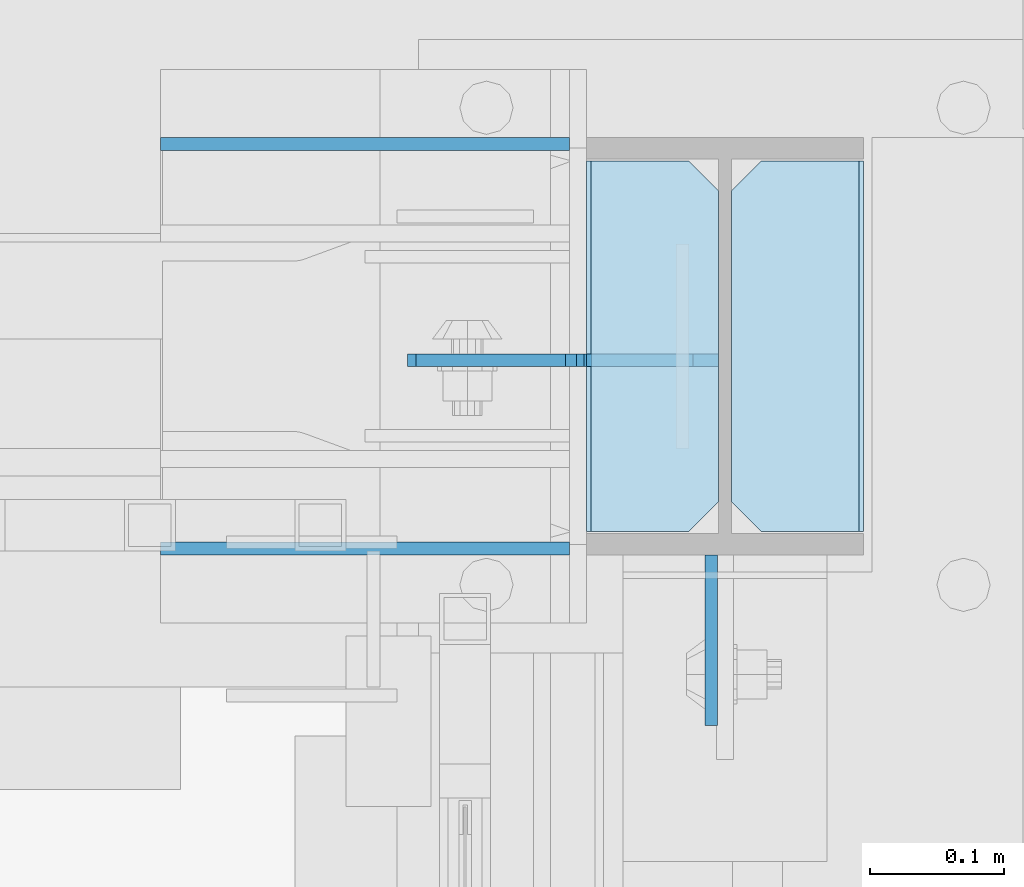
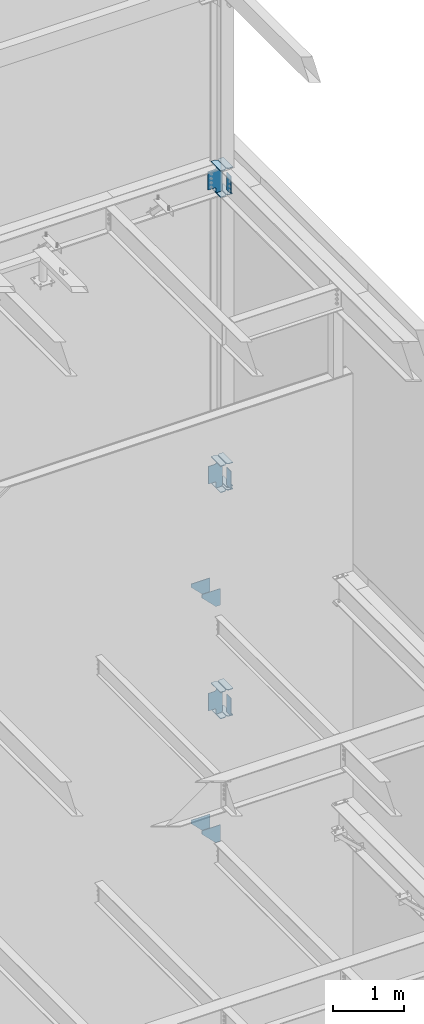
# One storey, part 1116 of 1179: 23 plates, 1 element without a shape of its own.
"""IFC2X3 building model written with IfcOpenShell, lengths in millimetres."""

from ifc_helpers import new_model, si_unit, frame, origin_with_axes, place, context, subcontext, project, spatial, faceted_brep, material, type_object, element, aggregate, save


model = new_model("IFC2X3")

# Units and contexts
model_context = context("Model", 3, precision=1e-05, world=origin_with_axes())
body_context = subcontext(model_context, "Body", "Model", "MODEL_VIEW")
ifc_project = project(units=[si_unit("LENGTHUNIT", "METRE", prefix="MILLI"), si_unit("AREAUNIT", "SQUARE_METRE"), si_unit("VOLUMEUNIT", "CUBIC_METRE"), si_unit("MASSUNIT", "GRAM", prefix="KILO"), si_unit("TIMEUNIT", "SECOND"), si_unit("PLANEANGLEUNIT", "RADIAN"), si_unit("SOLIDANGLEUNIT", "STERADIAN"), si_unit("THERMODYNAMICTEMPERATUREUNIT", "DEGREE_CELSIUS"), si_unit("LUMINOUSINTENSITYUNIT", "LUMEN")], contexts=[model_context])

# Site, building, storey
site_placement = place(None, origin_with_axes())
site = spatial("IfcSite", under=ifc_project, at=site_placement, CompositionType="ELEMENT")
building_placement = place(site_placement, origin_with_axes())
building = spatial("IfcBuilding", under=site, at=building_placement, Name="Undefined", CompositionType="ELEMENT")
storey_placement = place(building_placement, origin_with_axes())
storey = spatial("IfcBuildingStorey", under=building, at=storey_placement, Name="Undefined", CompositionType="ELEMENT", Elevation=0.0)

# Assembly, plates
assembly_placement = place(storey_placement, origin_with_axes())
assembly = element("IfcElementAssembly", 1, at=assembly_placement, inside=storey, Name="COLUMN", AssemblyPlace="NOTDEFINED", PredefinedType="RIGID_FRAME")
ifc_material = material(Name="STEEL/A36")
plate_type_1 = type_object("IfcPlateType", PredefinedType="NOTDEFINED")
plate_1_placement = place(assembly_placement, frame((24297.48125, 41043.225, 13081.0), z_axis=(0.0, -1.0, 0.0), x_axis=(0.0, 0.0, -1.0)))
plate_1 = element("IfcPlate", 2, at=plate_1_placement, type_object=plate_type_1, material=ifc_material, Name="PLATE", context=body_context, shape_type="Brep", body=[
    faceted_brep([(0.0, -4.76249999999709, 0.0), (0.0, -4.76249999999709, 127.0), (0.0, 4.76249999999709, 127.0), (0.0, 4.76249999999709, 0.0), (304.799999999999, -4.76249999999982, 127.0), (304.799999999999, 4.76249999999982, 127.0), (304.799987792969, -4.76250000000073, 0.0), (304.799987792969, 4.76250000000073, 0.0)], [[[0, 1, 2, 3]], [[2, 1, 4, 5]], [[4, 6, 7, 5]], [[6, 0, 3, 7]], [[5, 7, 3, 2]], [[6, 4, 1, 0]]]),
])
plate_2_placement = place(assembly_placement, frame((24297.48125, 41043.225, 7975.5999983942), z_axis=(0.0, -1.0, 0.0), x_axis=(0.0, 0.0, -1.0)))
plate_2 = element("IfcPlate", 3, at=plate_2_placement, type_object=plate_type_1, material=ifc_material, Name="PLATE", context=body_context, shape_type="Brep", body=[
    faceted_brep([(0.0, -4.76249999999709, 0.0), (0.0, -4.76249999999709, 127.0), (0.0, 4.76249999999709, 127.0), (0.0, 4.76249999999709, 0.0), (304.799999999999, -4.76249999999982, 127.0), (304.799999999999, 4.76249999999982, 127.0), (304.799987792969, -4.76250000000073, 0.0), (304.799987792969, 4.76250000000073, 0.0)], [[[0, 1, 2, 3]], [[2, 1, 4, 5]], [[4, 6, 7, 5]], [[6, 0, 3, 7]], [[5, 7, 3, 2]], [[6, 4, 1, 0]]]),
])
plate_3_placement = place(assembly_placement, frame((24297.48125, 41043.225, 4051.3), z_axis=(0.0, -1.0, 0.0), x_axis=(0.0, 0.0, -1.0)))
plate_3 = element("IfcPlate", 4, at=plate_3_placement, type_object=plate_type_1, material=ifc_material, Name="PLATE", context=body_context, shape_type="Brep", body=[
    faceted_brep([(0.0, -4.76249999999709, 0.0), (0.0, -4.76249999999709, 127.0), (0.0, 4.76249999999709, 127.0), (0.0, 4.76249999999709, 0.0), (304.799999999999, -4.76249999999982, 127.0), (304.799999999999, 4.76249999999982, 127.0), (304.799987792969, -4.76250000000073, 0.0), (304.799987792969, 4.76250000000073, 0.0)], [[[0, 1, 2, 3]], [[2, 1, 4, 5]], [[4, 6, 7, 5]], [[6, 0, 3, 7]], [[5, 7, 3, 2]], [[6, 4, 1, 0]]]),
])
plate_type_2 = type_object("IfcPlateType", PredefinedType="NOTDEFINED")
plate_4_placement = place(assembly_placement, frame((24312.5625, 41336.9125, 12658.725), z_axis=(0.0, -1.0, 0.0), x_axis=(1.0, 0.0, 0.0)))
plate_4 = element("IfcPlate", 5, at=plate_4_placement, type_object=plate_type_2, material=ifc_material, Name="PLATE", context=body_context, shape_type="Brep", body=[
    faceted_brep([(0.0, -6.34999999999854, 22.2250003814697), (0.0, -6.35000000000036, 254.000005722046), (0.0, 6.35000000000036, 254.000005722046), (0.0, 6.34999999999854, 22.2250003814697), (22.2250003814697, -6.35000000000036, 276.225006103516), (22.2250003814697, 6.35000000000036, 276.225006103516), (95.25, -6.35000000000036, 276.225006103516), (95.25, 6.35000000000036, 276.225006103516), (95.25, -6.34999999999309, 1.81898940354586e-12), (95.25, 6.34999999999854, -1.81898940354586e-12), (22.2250003814697, -6.34999999999854, 0.0), (22.2250003814697, 6.34999999999854, 0.0)], [[[0, 1, 2, 3]], [[1, 4, 5, 2]], [[4, 6, 7, 5]], [[6, 8, 9, 7]], [[8, 10, 11, 9]], [[10, 0, 3, 11]], [[5, 7, 9, 11, 3, 2]], [[10, 8, 6, 4, 1, 0]]]),
])
plate_5_placement = place(assembly_placement, frame((24312.5625, 41336.9125, 13112.75), z_axis=(0.0, -1.0, 0.0), x_axis=(1.0, 0.0, 0.0)))
plate_5 = element("IfcPlate", 6, at=plate_5_placement, type_object=plate_type_2, material=ifc_material, Name="PLATE", context=body_context, shape_type="Brep", body=[
    faceted_brep([(0.0, -6.34999999999854, 22.2250003814697), (0.0, -6.35000000000036, 254.000005722046), (0.0, 6.35000000000036, 254.000005722046), (0.0, 6.34999999999854, 22.2250003814697), (22.2250003814697, -6.35000000000036, 276.225006103516), (22.2250003814697, 6.35000000000036, 276.225006103516), (95.25, -6.35000000000036, 276.225006103516), (95.25, 6.35000000000036, 276.225006103516), (95.25, -6.34999999999309, 1.81898940354586e-12), (95.25, 6.34999999999854, -1.81898940354586e-12), (22.2250003814697, -6.34999999999854, 0.0), (22.2250003814697, 6.34999999999854, 0.0)], [[[0, 1, 2, 3]], [[1, 4, 5, 2]], [[4, 6, 7, 5]], [[6, 8, 9, 7]], [[8, 10, 11, 9]], [[10, 0, 3, 11]], [[5, 7, 9, 11, 3, 2]], [[10, 8, 6, 4, 1, 0]]]),
])
plate_6_placement = place(assembly_placement, frame((24207.7875, 41336.9125, 12658.725), z_axis=(0.0, -1.0, 0.0), x_axis=(1.0, 0.0, 0.0)))
plate_6 = element("IfcPlate", 7, at=plate_6_placement, type_object=plate_type_2, material=ifc_material, Name="PLATE", context=body_context, shape_type="Brep", body=[
    faceted_brep([(0.0, -6.34999999999854, 0.0), (0.0, -6.35000000000036, 276.225006103516), (0.0, 6.35000000000036, 276.225006103516), (0.0, 6.34999999999854, 0.0), (73.0249996185303, -6.35000000000036, 276.225006103516), (73.0249996185303, 6.35000000000036, 276.225006103516), (95.25, -6.35000000000036, 254.000005722046), (95.25, 6.35000000000036, 254.000005722046), (95.25, -6.35000000000036, 22.2250003814697), (95.25, 6.35000000000036, 22.2250003814697), (73.0249999999996, -6.34999999999854, 0.0), (73.0249999999996, 6.34999999999854, 0.0)], [[[0, 1, 2, 3]], [[1, 4, 5, 2]], [[4, 6, 7, 5]], [[6, 8, 9, 7]], [[8, 10, 11, 9]], [[10, 0, 3, 11]], [[5, 7, 9, 11, 3, 2]], [[10, 8, 6, 4, 1, 0]]]),
])
plate_7_placement = place(assembly_placement, frame((24207.7875, 41336.9125, 13112.75), z_axis=(0.0, -1.0, 0.0), x_axis=(1.0, 0.0, 0.0)))
plate_7 = element("IfcPlate", 8, at=plate_7_placement, type_object=plate_type_2, material=ifc_material, Name="PLATE", context=body_context, shape_type="Brep", body=[
    faceted_brep([(0.0, -6.34999999999854, 0.0), (0.0, -6.35000000000036, 276.225006103516), (0.0, 6.35000000000036, 276.225006103516), (0.0, 6.34999999999854, 0.0), (73.0249996185303, -6.35000000000036, 276.225006103516), (73.0249996185303, 6.35000000000036, 276.225006103516), (95.25, -6.35000000000036, 254.000005722046), (95.25, 6.35000000000036, 254.000005722046), (95.25, -6.35000000000036, 22.2250003814697), (95.25, 6.35000000000036, 22.2250003814697), (73.0249999999996, -6.34999999999854, 0.0), (73.0249999999996, 6.34999999999854, 0.0)], [[[0, 1, 2, 3]], [[1, 4, 5, 2]], [[4, 6, 7, 5]], [[6, 8, 9, 7]], [[8, 10, 11, 9]], [[10, 0, 3, 11]], [[5, 7, 9, 11, 3, 2]], [[10, 8, 6, 4, 1, 0]]]),
])
plate_8_placement = place(assembly_placement, frame((24407.8125, 41060.6875, 7604.125), z_axis=(0.0, 1.0, 0.0), x_axis=(-1.0, 0.0, 0.0)))
plate_8 = element("IfcPlate", 9, at=plate_8_placement, type_object=plate_type_2, material=ifc_material, Name="PLATE", context=body_context, shape_type="Brep", body=[
    faceted_brep([(0.0, -6.34999999999854, 0.0), (0.0, -6.35000000000036, 276.225006103516), (0.0, 6.35000000000036, 276.225006103516), (0.0, 6.34999999999854, 0.0), (73.0249996185303, -6.35000000000036, 276.225006103516), (73.0249996185303, 6.35000000000036, 276.225006103516), (95.25, -6.35000000000036, 254.000005722046), (95.25, 6.35000000000036, 254.000005722046), (95.25, -6.35000000000036, 22.2250003814697), (95.25, 6.35000000000036, 22.2250003814697), (73.0249999999996, -6.34999999999854, 0.0), (73.0249999999996, 6.34999999999854, 0.0)], [[[0, 1, 2, 3]], [[1, 4, 5, 2]], [[4, 6, 7, 5]], [[6, 8, 9, 7]], [[8, 10, 11, 9]], [[10, 0, 3, 11]], [[5, 7, 9, 11, 3, 2]], [[10, 8, 6, 4, 1, 0]]]),
])
plate_9_placement = place(assembly_placement, frame((24312.5625, 41336.9125, 7553.325), z_axis=(0.0, -1.0, 0.0), x_axis=(1.0, 0.0, 0.0)))
plate_9 = element("IfcPlate", 10, at=plate_9_placement, type_object=plate_type_2, material=ifc_material, Name="PLATE", context=body_context, shape_type="Brep", body=[
    faceted_brep([(0.0, -6.34999999999854, 22.2250003814697), (0.0, -6.35000000000036, 254.000005722046), (0.0, 6.35000000000036, 254.000005722046), (0.0, 6.34999999999854, 22.2250003814697), (22.2250003814697, -6.35000000000036, 276.225006103516), (22.2250003814697, 6.35000000000036, 276.225006103516), (95.25, -6.35000000000036, 276.225006103516), (95.25, 6.35000000000036, 276.225006103516), (95.25, -6.34999999999309, 1.81898940354586e-12), (95.25, 6.34999999999854, -1.81898940354586e-12), (22.2250003814697, -6.34999999999854, 0.0), (22.2250003814697, 6.34999999999854, 0.0)], [[[0, 1, 2, 3]], [[1, 4, 5, 2]], [[4, 6, 7, 5]], [[6, 8, 9, 7]], [[8, 10, 11, 9]], [[10, 0, 3, 11]], [[5, 7, 9, 11, 3, 2]], [[10, 8, 6, 4, 1, 0]]]),
])
plate_10_placement = place(assembly_placement, frame((24312.5625, 41336.9125, 8007.35), z_axis=(0.0, -1.0, 0.0), x_axis=(1.0, 0.0, 0.0)))
plate_10 = element("IfcPlate", 11, at=plate_10_placement, type_object=plate_type_2, material=ifc_material, Name="PLATE", context=body_context, shape_type="Brep", body=[
    faceted_brep([(0.0, -6.34999999999854, 22.2250003814697), (0.0, -6.35000000000036, 254.000005722046), (0.0, 6.35000000000036, 254.000005722046), (0.0, 6.34999999999854, 22.2250003814697), (22.2250003814697, -6.35000000000036, 276.225006103516), (22.2250003814697, 6.35000000000036, 276.225006103516), (95.25, -6.35000000000036, 276.225006103516), (95.25, 6.35000000000036, 276.225006103516), (95.25, -6.34999999999309, 1.81898940354586e-12), (95.25, 6.34999999999854, -1.81898940354586e-12), (22.2250003814697, -6.34999999999854, 0.0), (22.2250003814697, 6.34999999999854, 0.0)], [[[0, 1, 2, 3]], [[1, 4, 5, 2]], [[4, 6, 7, 5]], [[6, 8, 9, 7]], [[8, 10, 11, 9]], [[10, 0, 3, 11]], [[5, 7, 9, 11, 3, 2]], [[10, 8, 6, 4, 1, 0]]]),
])
plate_11_placement = place(assembly_placement, frame((24207.7875, 41336.9125, 7553.325), z_axis=(0.0, -1.0, 0.0), x_axis=(1.0, 0.0, 0.0)))
plate_11 = element("IfcPlate", 12, at=plate_11_placement, type_object=plate_type_2, material=ifc_material, Name="PLATE", context=body_context, shape_type="Brep", body=[
    faceted_brep([(0.0, -6.34999999999854, 0.0), (0.0, -6.35000000000036, 276.225006103516), (0.0, 6.35000000000036, 276.225006103516), (0.0, 6.34999999999854, 0.0), (73.0249996185303, -6.35000000000036, 276.225006103516), (73.0249996185303, 6.35000000000036, 276.225006103516), (95.25, -6.35000000000036, 254.000005722046), (95.25, 6.35000000000036, 254.000005722046), (95.25, -6.35000000000036, 22.2250003814697), (95.25, 6.35000000000036, 22.2250003814697), (73.0249999999996, -6.34999999999854, 0.0), (73.0249999999996, 6.34999999999854, 0.0)], [[[0, 1, 2, 3]], [[1, 4, 5, 2]], [[4, 6, 7, 5]], [[6, 8, 9, 7]], [[8, 10, 11, 9]], [[10, 0, 3, 11]], [[5, 7, 9, 11, 3, 2]], [[10, 8, 6, 4, 1, 0]]]),
])
plate_12_placement = place(assembly_placement, frame((24207.7875, 41336.9125, 8007.35), z_axis=(0.0, -1.0, 0.0), x_axis=(1.0, 0.0, 0.0)))
plate_12 = element("IfcPlate", 13, at=plate_12_placement, type_object=plate_type_2, material=ifc_material, Name="PLATE", context=body_context, shape_type="Brep", body=[
    faceted_brep([(0.0, -6.34999999999854, 0.0), (0.0, -6.35000000000036, 276.225006103516), (0.0, 6.35000000000036, 276.225006103516), (0.0, 6.34999999999854, 0.0), (73.0249996185303, -6.35000000000036, 276.225006103516), (73.0249996185303, 6.35000000000036, 276.225006103516), (95.25, -6.35000000000036, 254.000005722046), (95.25, 6.35000000000036, 254.000005722046), (95.25, -6.35000000000036, 22.2250003814697), (95.25, 6.35000000000036, 22.2250003814697), (73.0249999999996, -6.34999999999854, 0.0), (73.0249999999996, 6.34999999999854, 0.0)], [[[0, 1, 2, 3]], [[1, 4, 5, 2]], [[4, 6, 7, 5]], [[6, 8, 9, 7]], [[8, 10, 11, 9]], [[10, 0, 3, 11]], [[5, 7, 9, 11, 3, 2]], [[10, 8, 6, 4, 1, 0]]]),
])
plate_type_3 = type_object("IfcPlateType", PredefinedType="NOTDEFINED")
plate_13_placement = place(assembly_placement, frame((24303.0375, 41188.4807500839, 7578.725), z_axis=(-0.707106781186532, 0.0, 0.707106781186563), x_axis=(-0.707106781186564, 0.0, -0.707106781186531)))
plate_13 = element("IfcPlate", 14, at=plate_13_placement, type_object=plate_type_3, material=ifc_material, Name="PLATE", context=body_context, shape_type="Brep", body=[
    faceted_brep([(0.0, -4.76249999999709, 0.0), (-285.12313184404, -4.76249999999709, 285.12313184404), (-285.12313184404, 4.76249999999709, 285.12313184404), (0.0, 4.76249999999709, 0.0), (-285.123131844106, -4.76249999999709, 312.063900207191), (-285.123131844106, 4.76249999999709, 312.063900207191), (-228.996531087698, -4.76249999999709, 368.190500963599), (-228.996531087698, 4.76249999999709, 368.190500963599), (-220.756177881638, -4.76249999999709, 362.684472892908), (-220.756177881638, 4.76249999999709, 362.684472892908), (-211.036018845556, -4.76249999999709, 360.751013047719), (-211.036018845556, 4.76249999999709, 360.751013047719), (-201.315859809478, -4.76249999999709, 362.684472892883), (-201.315859809478, 4.76249999999709, 362.684472892883), (-193.075506873185, -4.76249999999709, 368.19050069382), (-193.075506873185, 4.76249999999709, 368.19050069382), (-121.233457635277, -4.76249999999709, 440.03254993172), (-121.233457635277, 4.76249999999709, 440.03254993172), (94.2926892704454, -4.76249999999709, 224.506403025976), (94.2926892704454, 4.76249999999709, 224.506403025976), (22.4506400325372, -4.76249999999709, 152.664353788075), (22.4506400325372, 4.76249999999709, 152.664353788075), (16.9446122315967, -4.76249999999709, 144.424000851788), (16.9446122315967, 4.76249999999709, 144.424000851788), (15.0111523864362, -4.76249999999709, 134.703841815706), (15.0111523864362, 4.76249999999709, 134.703841815706), (16.9446122316185, -4.76249999999709, 124.983682779626), (16.9446122316185, 4.76249999999709, 124.983682779626), (22.4506400325808, -4.76249999999709, 116.743329843322), (22.4506400325808, 4.76249999999709, 116.743329843322), (83.0673691195552, -4.76249999999709, 56.126600756339), (83.0673691195552, 4.76249999999709, 56.126600756339), (26.9407683631525, -4.76249999999709, -6.18456397205591e-11), (26.9407683631525, 4.76249999999709, -6.18456397205591e-11)], [[[0, 1, 2, 3]], [[1, 4, 5, 2]], [[4, 6, 7, 5]], [[6, 8, 9, 7]], [[8, 10, 11, 9]], [[10, 12, 13, 11]], [[12, 14, 15, 13]], [[14, 16, 17, 15]], [[16, 18, 19, 17]], [[18, 20, 21, 19]], [[20, 22, 23, 21]], [[22, 24, 25, 23]], [[24, 26, 27, 25]], [[26, 28, 29, 27]], [[28, 30, 31, 29]], [[30, 32, 33, 31]], [[32, 0, 3, 33]], [[5, 7, 9, 11, 13, 15, 17, 19, 21, 23, 25, 27, 29, 31, 33, 3, 2]], [[32, 30, 28, 26, 24, 22, 20, 18, 16, 14, 12, 10, 8, 6, 4, 1, 0]]]),
])
plate_14_placement = place(assembly_placement, frame((24303.0375, 41188.4807500839, 3667.125), z_axis=(-0.707106781186532, 0.0, 0.707106781186563), x_axis=(-0.707106781186564, 0.0, -0.707106781186531)))
plate_14 = element("IfcPlate", 15, at=plate_14_placement, type_object=plate_type_3, material=ifc_material, Name="PLATE", context=body_context, shape_type="Brep", body=[
    faceted_brep([(0.0, -4.76249999999709, 0.0), (-285.12313184404, -4.76249999999709, 285.12313184404), (-285.12313184404, 4.76249999999709, 285.12313184404), (0.0, 4.76249999999709, 0.0), (-285.123131844106, -4.76249999999709, 312.063900207191), (-285.123131844106, 4.76249999999709, 312.063900207191), (-228.996531087698, -4.76249999999709, 368.190500963599), (-228.996531087698, 4.76249999999709, 368.190500963599), (-220.016274696889, -4.76249999999709, 359.210244572785), (-220.016274696889, 4.76249999999709, 359.210244572785), (-211.775921760582, -4.76249999999709, 353.704216771825), (-211.775921760582, 4.76249999999709, 353.704216771825), (-202.0557627245, -4.76249999999709, 351.770756926639), (-202.0557627245, 4.76249999999709, 351.770756926639), (-192.335603688422, -4.76249999999709, 353.704216771799), (-192.335603688422, 4.76249999999709, 353.704216771799), (-184.095250752132, -4.76249999999709, 359.21024457274), (-184.095250752132, 4.76249999999709, 359.21024457274), (-112.253201514228, -4.76249999999709, 431.052293810644), (-112.253201514228, 4.76249999999709, 431.052293810644), (103.272945391505, -4.76249999999709, 215.526146904915), (103.272945391505, 4.76249999999709, 215.526146904915), (31.4308961536044, -4.76249999999709, 143.68409766701), (31.4308961536044, 4.76249999999709, 143.68409766701), (25.9248683526639, -4.76249999999709, 135.443744730717), (25.9248683526639, 4.76249999999709, 135.443744730717), (23.9914085075034, -4.76249999999709, 125.723585694639), (23.9914085075034, 4.76249999999709, 125.723585694639), (25.924868352693, -4.76249999999709, 116.003426658557), (25.924868352693, 4.76249999999709, 116.003426658557), (31.4308961536517, -4.76249999999709, 107.763073722252), (31.4308961536517, 4.76249999999709, 107.763073722252), (83.0673691195552, -4.76249999999709, 56.126600756339), (83.0673691195552, 4.76249999999709, 56.126600756339), (26.9407683631525, -4.76249999999709, -6.18456397205591e-11), (26.9407683631525, 4.76249999999709, -6.18456397205591e-11)], [[[0, 1, 2, 3]], [[1, 4, 5, 2]], [[4, 6, 7, 5]], [[6, 8, 9, 7]], [[8, 10, 11, 9]], [[10, 12, 13, 11]], [[12, 14, 15, 13]], [[14, 16, 17, 15]], [[16, 18, 19, 17]], [[18, 20, 21, 19]], [[20, 22, 23, 21]], [[22, 24, 25, 23]], [[24, 26, 27, 25]], [[26, 28, 29, 27]], [[28, 30, 31, 29]], [[30, 32, 33, 31]], [[32, 34, 35, 33]], [[34, 0, 3, 35]], [[5, 7, 9, 11, 13, 15, 17, 19, 21, 23, 25, 27, 29, 31, 33, 35, 3, 2]], [[34, 32, 30, 28, 26, 24, 22, 20, 18, 16, 14, 12, 10, 8, 6, 4, 1, 0]]]),
])
plate_type_4 = type_object("IfcPlateType", PredefinedType="NOTDEFINED")
plate_15_placement = place(assembly_placement, frame((23887.112512207, 41349.6125, 5911.85), z_axis=(1.0, 0.0, 0.0), x_axis=(0.0, 0.0, -1.0)))
plate_15 = element("IfcPlate", 16, at=plate_15_placement, type_object=plate_type_4, material=ifc_material, Name="PLATE", context=body_context, shape_type="Brep", body=[
    faceted_brep([(0.0, -4.76249999999709, 0.0), (0.0, -4.76249999999709, 304.799987792969), (0.0, 4.76249999999709, 304.799987792969), (0.0, 4.76249999999709, 0.0), (285.75, -4.76249999999709, 304.799987792969), (285.75, 4.76249999999709, 304.799987792969), (285.75, -4.76249999999709, 228.736236572266), (285.75, 4.76249999999709, 228.736236572266), (57.1500015258789, -4.76250000000073, 0.0), (57.1500015258789, 4.76250000000073, 0.0)], [[[0, 1, 2, 3]], [[1, 4, 5, 2]], [[4, 6, 7, 5]], [[6, 8, 9, 7]], [[8, 0, 3, 9]], [[5, 7, 9, 3, 2]], [[8, 6, 4, 1, 0]]]),
])
plate_16_placement = place(assembly_placement, frame((23887.1125126018, 41047.9875, 5911.85), z_axis=(1.0, 0.0, 0.0), x_axis=(0.0, 0.0, -1.0)))
plate_16 = element("IfcPlate", 17, at=plate_16_placement, type_object=plate_type_4, material=ifc_material, Name="PLATE", context=body_context, shape_type="Brep", body=[
    faceted_brep([(0.0, -4.76249999999709, 0.0), (0.0, -4.76249999999709, 304.799987792969), (0.0, 4.76249999999709, 304.799987792969), (0.0, 4.76249999999709, 0.0), (285.75, -4.76249999999709, 304.799987792969), (285.75, 4.76249999999709, 304.799987792969), (285.75, -4.76249999999709, 228.736236572266), (285.75, 4.76249999999709, 228.736236572266), (57.1500015258789, -4.76250000000073, 0.0), (57.1500015258789, 4.76250000000073, 0.0)], [[[0, 1, 2, 3]], [[1, 4, 5, 2]], [[4, 6, 7, 5]], [[6, 8, 9, 7]], [[8, 0, 3, 9]], [[5, 7, 9, 3, 2]], [[8, 6, 4, 1, 0]]]),
])
plate_17_placement = place(assembly_placement, frame((23887.112512207, 41349.6125, 1825.625), z_axis=(1.0, 0.0, 0.0), x_axis=(0.0, 0.0, -1.0)))
plate_17 = element("IfcPlate", 18, at=plate_17_placement, type_object=plate_type_4, material=ifc_material, Name="PLATE", context=body_context, shape_type="Brep", body=[
    faceted_brep([(0.0, -4.76249999999709, 0.0), (0.0, -4.76249999999709, 304.799987792969), (0.0, 4.76249999999709, 304.799987792969), (0.0, 4.76249999999709, 0.0), (285.75, -4.76249999999709, 304.799987792969), (285.75, 4.76249999999709, 304.799987792969), (285.75, -4.76249999999709, 228.736236572266), (285.75, 4.76249999999709, 228.736236572266), (57.1500015258789, -4.76250000000073, 0.0), (57.1500015258789, 4.76250000000073, 0.0)], [[[0, 1, 2, 3]], [[1, 4, 5, 2]], [[4, 6, 7, 5]], [[6, 8, 9, 7]], [[8, 0, 3, 9]], [[5, 7, 9, 3, 2]], [[8, 6, 4, 1, 0]]]),
])
plate_18_placement = place(assembly_placement, frame((23887.1125126018, 41047.9875, 1825.625), z_axis=(1.0, 0.0, 0.0), x_axis=(0.0, 0.0, -1.0)))
plate_18 = element("IfcPlate", 19, at=plate_18_placement, type_object=plate_type_4, material=ifc_material, Name="PLATE", context=body_context, shape_type="Brep", body=[
    faceted_brep([(0.0, -4.76249999999709, 0.0), (0.0, -4.76249999999709, 304.799987792969), (0.0, 4.76249999999709, 304.799987792969), (0.0, 4.76249999999709, 0.0), (285.75, -4.76249999999709, 304.799987792969), (285.75, 4.76249999999709, 304.799987792969), (285.75, -4.76249999999709, 228.736236572266), (285.75, 4.76249999999709, 228.736236572266), (57.1500015258789, -4.76250000000073, 0.0), (57.1500015258789, 4.76250000000073, 0.0)], [[[0, 1, 2, 3]], [[1, 4, 5, 2]], [[4, 6, 7, 5]], [[6, 8, 9, 7]], [[8, 0, 3, 9]], [[5, 7, 9, 3, 2]], [[8, 6, 4, 1, 0]]]),
])
plate_type_5 = type_object("IfcPlateType", PredefinedType="NOTDEFINED")
plate_19_placement = place(assembly_placement, frame((24303.0375, 41188.48125, 12684.125), z_axis=(-0.707106781186532, 0.0, 0.707106781186563), x_axis=(-0.707106781186564, 0.0, -0.707106781186531)))
plate_19 = element("IfcPlate", 20, at=plate_19_placement, type_object=plate_type_5, material=ifc_material, Name="PLATE", context=body_context, shape_type="Brep", body=[
    faceted_brep([(0.0, -4.76249999999709, 0.0), (-285.12313184404, -4.76249999999709, 285.12313184404), (-285.12313184404, 4.76249999999709, 285.12313184404), (0.0, 4.76249999999709, 0.0), (-285.123131844106, -4.76249999999709, 312.063900207191), (-285.123131844106, 4.76249999999709, 312.063900207191), (-228.996531087698, -4.76249999999709, 368.190500963599), (-228.996531087698, 4.76249999999709, 368.190500963599), (-224.506402757423, -4.76249999999709, 363.700372633322), (-224.506402757423, 4.76249999999709, 363.700372633322), (-216.266049821123, -4.76249999999709, 358.19434483236), (-216.266049821123, 4.76249999999709, 358.19434483236), (-206.545890785033, -4.76249999999709, 356.260884987176), (-206.545890785033, 4.76249999999709, 356.260884987176), (-196.825731748955, -4.76249999999709, 358.194344832336), (-196.825731748955, 4.76249999999709, 358.194344832336), (-188.585378812666, -4.76249999999709, 363.700372633273), (-188.585378812666, 4.76249999999709, 363.700372633273), (-112.253201514242, -4.76249999999709, 440.032549931697), (-112.253201514242, 4.76249999999709, 440.032549931697), (112.253201512562, -4.76249999999709, 215.526146904893), (112.253201512562, 4.76249999999709, 215.526146904893), (35.921024214138, -4.76249999999709, 139.193969606469), (35.921024214138, 4.76249999999709, 139.193969606469), (30.4149964132012, -4.76249999999709, 130.95361667018), (30.4149964132012, 4.76249999999709, 130.95361667018), (28.4815365680406, -4.76249999999709, 121.233457634102), (28.4815365680406, 4.76249999999709, 121.233457634102), (30.414996413223, -4.76249999999709, 111.513298598016), (30.414996413223, 4.76249999999709, 111.513298598016), (35.9210242141889, -4.76249999999709, 103.272945661714), (35.9210242141889, 4.76249999999709, 103.272945661714), (83.0673691195552, -4.76249999999709, 56.126600756339), (83.0673691195552, 4.76249999999709, 56.126600756339), (26.9407683631525, -4.76249999999709, -6.18456397205591e-11), (26.9407683631525, 4.76249999999709, -6.18456397205591e-11)], [[[0, 1, 2, 3]], [[1, 4, 5, 2]], [[4, 6, 7, 5]], [[6, 8, 9, 7]], [[8, 10, 11, 9]], [[10, 12, 13, 11]], [[12, 14, 15, 13]], [[14, 16, 17, 15]], [[16, 18, 19, 17]], [[18, 20, 21, 19]], [[20, 22, 23, 21]], [[22, 24, 25, 23]], [[24, 26, 27, 25]], [[26, 28, 29, 27]], [[28, 30, 31, 29]], [[30, 32, 33, 31]], [[32, 34, 35, 33]], [[34, 0, 3, 35]], [[5, 7, 9, 11, 13, 15, 17, 19, 21, 23, 25, 27, 29, 31, 33, 35, 3, 2]], [[34, 32, 30, 28, 26, 24, 22, 20, 18, 16, 14, 12, 10, 8, 6, 4, 1, 0]]]),
])
plate_type_6 = type_object("IfcPlateType", PredefinedType="NOTDEFINED")
plate_20_placement = place(assembly_placement, frame((24312.5625, 41336.9125, 3641.72499999999), z_axis=(0.0, -1.0, 0.0), x_axis=(1.0, 0.0, 0.0)))
plate_20 = element("IfcPlate", 21, at=plate_20_placement, type_object=plate_type_6, material=ifc_material, Name="PLATE", context=body_context, shape_type="Brep", body=[
    faceted_brep([(0.0, -6.34999999999854, 22.2250003814697), (0.0, -6.35000000000036, 254.000005722046), (0.0, 6.35000000000036, 254.000005722046), (0.0, 6.34999999999854, 22.2250003814697), (22.2250003814697, -6.35000000000036, 276.225006103516), (22.2250003814697, 6.35000000000036, 276.225006103516), (98.4249999999993, -6.34999999999991, 276.224999999999), (98.4249999999993, 6.34999999999991, 276.224999999999), (98.4250011444092, -6.35000000000036, 0.0), (98.4250011444092, 6.35000000000036, 0.0), (22.2250003814697, -6.34999999999854, 0.0), (22.2250003814697, 6.34999999999854, 0.0)], [[[0, 1, 2, 3]], [[1, 4, 5, 2]], [[4, 6, 7, 5]], [[6, 8, 9, 7]], [[8, 10, 11, 9]], [[10, 0, 3, 11]], [[5, 7, 9, 11, 3, 2]], [[10, 8, 6, 4, 1, 0]]]),
])
plate_21_placement = place(assembly_placement, frame((24312.5625, 41336.9125, 4095.75), z_axis=(0.0, -1.0, 0.0), x_axis=(1.0, 0.0, 0.0)))
plate_21 = element("IfcPlate", 22, at=plate_21_placement, type_object=plate_type_6, material=ifc_material, Name="PLATE", context=body_context, shape_type="Brep", body=[
    faceted_brep([(0.0, -6.34999999999854, 22.2250003814697), (0.0, -6.35000000000036, 254.000005722046), (0.0, 6.35000000000036, 254.000005722046), (0.0, 6.34999999999854, 22.2250003814697), (22.2250003814697, -6.35000000000036, 276.225006103516), (22.2250003814697, 6.35000000000036, 276.225006103516), (98.4249999999993, -6.34999999999991, 276.224999999999), (98.4249999999993, 6.34999999999991, 276.224999999999), (98.4250011444092, -6.35000000000036, 0.0), (98.4250011444092, 6.35000000000036, 0.0), (22.2250003814697, -6.34999999999854, 0.0), (22.2250003814697, 6.34999999999854, 0.0)], [[[0, 1, 2, 3]], [[1, 4, 5, 2]], [[4, 6, 7, 5]], [[6, 8, 9, 7]], [[8, 10, 11, 9]], [[10, 0, 3, 11]], [[5, 7, 9, 11, 3, 2]], [[10, 8, 6, 4, 1, 0]]]),
])
plate_22_placement = place(assembly_placement, frame((24204.6125, 41336.9125, 3641.725), z_axis=(0.0, -1.0, 0.0), x_axis=(1.0, 0.0, 0.0)))
plate_22 = element("IfcPlate", 23, at=plate_22_placement, type_object=plate_type_6, material=ifc_material, Name="PLATE", context=body_context, shape_type="Brep", body=[
    faceted_brep([(0.0, -6.34999999999854, 0.0), (0.0, -6.35000000000036, 276.225006103516), (0.0, 6.35000000000036, 276.225006103516), (0.0, 6.34999999999854, 0.0), (76.1999996185295, -6.34999999999991, 276.224999999999), (76.1999996185295, 6.34999999999991, 276.224999999999), (98.4249999999993, -6.34999999999991, 253.999999618529), (98.4249999999993, 6.34999999999991, 253.999999618529), (98.4249999999993, -6.34999999999991, 22.2250003814697), (98.4249999999993, 6.34999999999991, 22.2250003814697), (76.2000007629395, -6.35000000000218, 0.0), (76.2000007629395, 6.34999999999491, 3.63797880709171e-12)], [[[0, 1, 2, 3]], [[1, 4, 5, 2]], [[4, 6, 7, 5]], [[6, 8, 9, 7]], [[8, 10, 11, 9]], [[10, 0, 3, 11]], [[5, 7, 9, 11, 3, 2]], [[10, 8, 6, 4, 1, 0]]]),
])
plate_23_placement = place(assembly_placement, frame((24204.6125, 41336.9125, 4095.75), z_axis=(0.0, -1.0, 0.0), x_axis=(1.0, 0.0, 0.0)))
plate_23 = element("IfcPlate", 24, at=plate_23_placement, type_object=plate_type_6, material=ifc_material, Name="PLATE", context=body_context, shape_type="Brep", body=[
    faceted_brep([(0.0, -6.34999999999854, 0.0), (0.0, -6.35000000000036, 276.225006103516), (0.0, 6.35000000000036, 276.225006103516), (0.0, 6.34999999999854, 0.0), (76.1999996185295, -6.34999999999991, 276.224999999999), (76.1999996185295, 6.34999999999991, 276.224999999999), (98.4249999999993, -6.34999999999991, 253.999999618529), (98.4249999999993, 6.34999999999991, 253.999999618529), (98.4249999999993, -6.34999999999991, 22.2250003814697), (98.4249999999993, 6.34999999999991, 22.2250003814697), (76.2000007629395, -6.35000000000218, 0.0), (76.2000007629395, 6.34999999999491, 3.63797880709171e-12)], [[[0, 1, 2, 3]], [[1, 4, 5, 2]], [[4, 6, 7, 5]], [[6, 8, 9, 7]], [[8, 10, 11, 9]], [[10, 0, 3, 11]], [[5, 7, 9, 11, 3, 2]], [[10, 8, 6, 4, 1, 0]]]),
])
aggregate(assembly, [plate_15, plate_16, plate_4, plate_5, plate_6, plate_7, plate_19, plate_1, plate_8, plate_2, plate_9, plate_10, plate_11, plate_12, plate_13, plate_3, plate_20, plate_21, plate_22, plate_23, plate_14, plate_17, plate_18])

save(model, "model.ifc")
